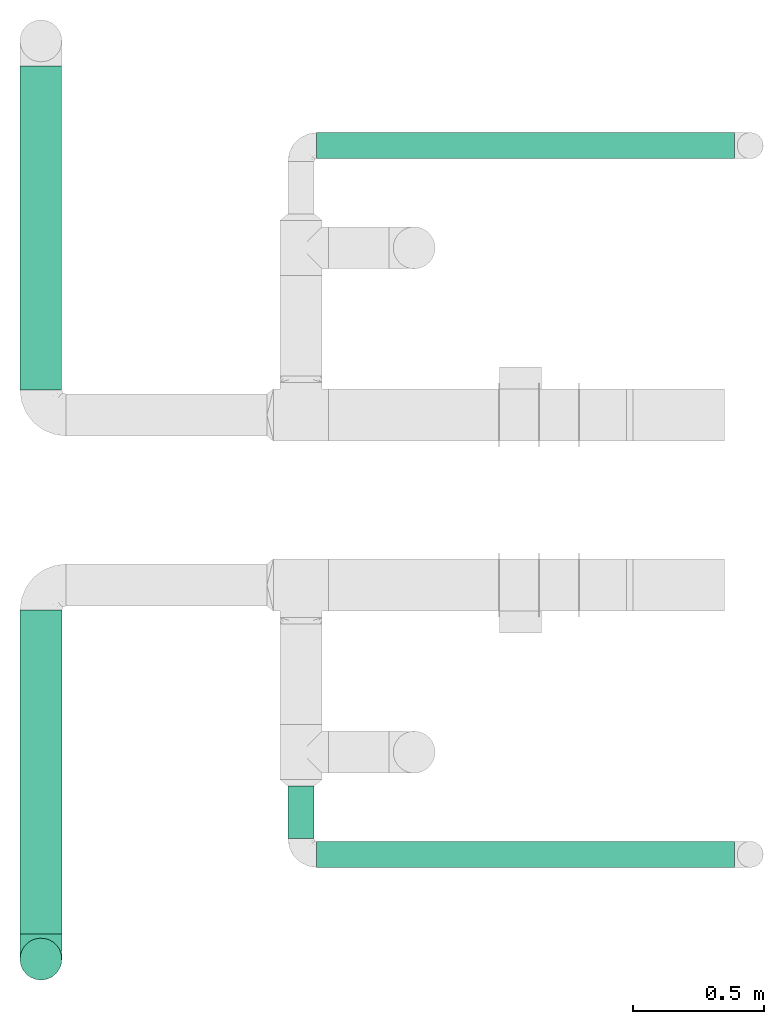
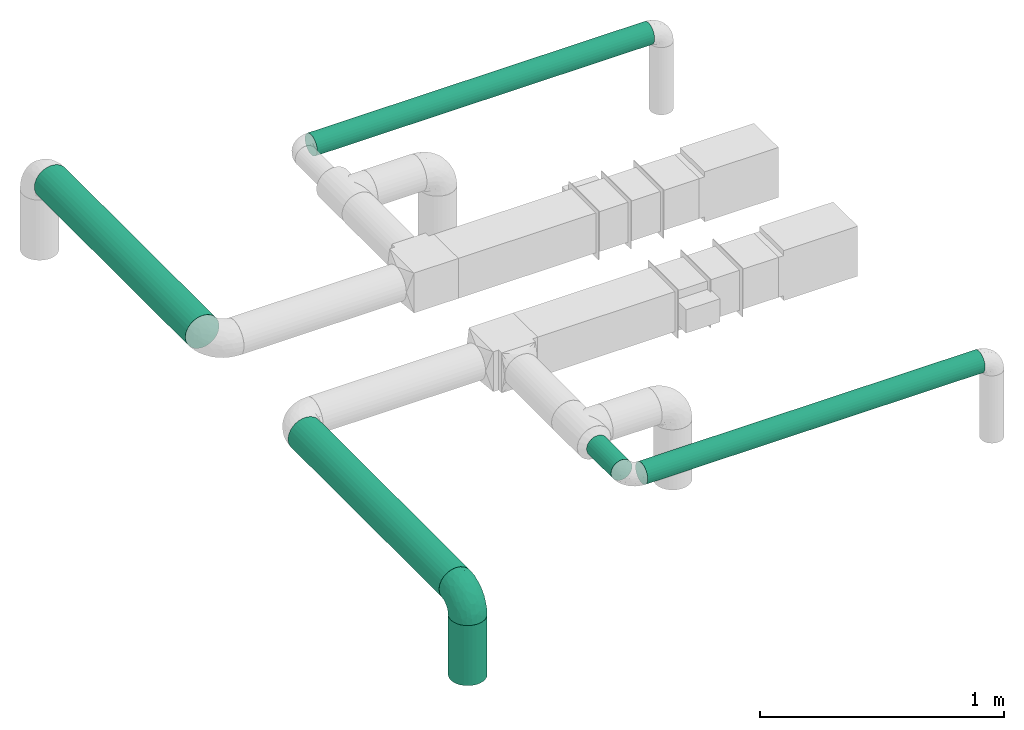
# One storey, part 1 of 12: 6 flow segments, 1 flow fitting.
"""IFC2X3 building model written with IfcOpenShell, lengths in millimetres."""

from ifc_helpers import new_model, entity, si_unit, converted_unit, derived_unit, direction, frame, frame_2d, origin, origin_2d_with_axis, place, context, subcontext, project, spatial, circle, extrude, faceted_brep, source, transform, mapped, type_object, type_shapes, element, save


model = new_model("IFC2X3")

# Units and contexts
model_context = context("Model", 3, precision=0.01, world=origin(), true_north=direction((6.12303176911189e-17, 1.0)))
body_context = subcontext(model_context, "Body", "Model", "MODEL_VIEW")
ifc_project = project(units=[si_unit("LENGTHUNIT", "METRE", prefix="MILLI"), si_unit("AREAUNIT", "SQUARE_METRE"), si_unit("VOLUMEUNIT", "CUBIC_METRE"), converted_unit("PLANEANGLEUNIT", "DEGREE", entity("IfcRatioMeasure", 0.0174532925199433), si_unit("PLANEANGLEUNIT", "RADIAN"), dimensions=[0, 0, 0, 0, 0, 0, 0]), si_unit("MASSUNIT", "GRAM", prefix="KILO"), derived_unit("MASSDENSITYUNIT", [(si_unit("MASSUNIT", "GRAM", prefix="KILO"), 1), (si_unit("LENGTHUNIT", "METRE"), -3)]), si_unit("TIMEUNIT", "SECOND"), si_unit("FREQUENCYUNIT", "HERTZ"), si_unit("THERMODYNAMICTEMPERATUREUNIT", "DEGREE_CELSIUS"), derived_unit("THERMALTRANSMITTANCEUNIT", [(si_unit("MASSUNIT", "GRAM", prefix="KILO"), 1), (si_unit("THERMODYNAMICTEMPERATUREUNIT", "KELVIN"), -1), (si_unit("TIMEUNIT", "SECOND"), -3)]), derived_unit("VOLUMETRICFLOWRATEUNIT", [(si_unit("LENGTHUNIT", "METRE"), 3), (si_unit("TIMEUNIT", "SECOND"), -1)]), si_unit("ELECTRICCURRENTUNIT", "AMPERE"), si_unit("ELECTRICVOLTAGEUNIT", "VOLT"), si_unit("POWERUNIT", "WATT"), si_unit("FORCEUNIT", "NEWTON", prefix="KILO"), si_unit("ILLUMINANCEUNIT", "LUX"), si_unit("LUMINOUSFLUXUNIT", "LUMEN"), si_unit("LUMINOUSINTENSITYUNIT", "CANDELA"), derived_unit("USERDEFINED", [(si_unit("MASSUNIT", "GRAM", prefix="KILO"), -1), (si_unit("LENGTHUNIT", "METRE"), -2), (si_unit("TIMEUNIT", "SECOND"), 3), (si_unit("LUMINOUSFLUXUNIT", "LUMEN"), 1)]), derived_unit("LINEARVELOCITYUNIT", [(si_unit("LENGTHUNIT", "METRE"), 1), (si_unit("TIMEUNIT", "SECOND"), -1)]), si_unit("PRESSUREUNIT", "PASCAL"), derived_unit("USERDEFINED", [(si_unit("LENGTHUNIT", "METRE"), -2), (si_unit("MASSUNIT", "GRAM", prefix="KILO"), 1), (si_unit("TIMEUNIT", "SECOND"), -2)])], contexts=[model_context])

# Site, building, storey
site_placement = place(None, origin())
site = spatial("IfcSite", under=ifc_project, at=site_placement, CompositionType="ELEMENT")
building_placement = place(site_placement, origin())
building = spatial("IfcBuilding", under=site, at=building_placement, CompositionType="ELEMENT")
storey_placement = place(building_placement, frame((0.0, 0.0, 8000.0)))
storey = spatial("IfcBuildingStorey", under=building, at=storey_placement, Name="02 Level", CompositionType="ELEMENT", Elevation=8000.0)

# Flow segments
duct_segment_type = type_object("IfcDuctSegmentType", Name="Round Duct:Air", PredefinedType="NOTDEFINED")
flow_segment_1_placement = place(storey_placement, frame((23245.9900708518, -70237.5308847274, 2948.40472776403)))
element("IfcFlowSegment", 1, at=flow_segment_1_placement, inside=storey, type_object=duct_segment_type, Name="Round Duct:Air", ObjectType="Round Duct:Air", context=body_context, shape_type="SweptSolid", body=[
    extrude(circle(Radius=50.0, at=origin_2d_with_axis()), frame((0.0, 51.5952722359132, 51.5952722359154), z_axis=(1.0, 0.0, 0.0), x_axis=(0.0, -1.0, 0.0)), (0.0, 0.0, 1.0), 1597.50000000001),
])
flow_segment_2_placement = place(storey_placement, frame((22110.1537099681, -70490.2395851399, 2918.40472776409)))
element("IfcFlowSegment", 2, at=flow_segment_2_placement, inside=storey, type_object=duct_segment_type, Name="Round Duct:Air", ObjectType="Round Duct:Air", context=body_context, shape_type="SweptSolid", body=[
    extrude(circle(Radius=80.0, at=origin_2d_with_axis()), frame((81.595272235915, 0.0, 81.595272235915), z_axis=(0.0, 1.0, 0.0), x_axis=(1.0, 0.0, 0.0)), (0.0, 0.0, 1.0), 1238.20435582267),
])
flow_segment_3_placement = place(storey_placement, frame((22110.1537099681, -70667.8348573758, 2603.07847999999)))
element("IfcFlowSegment", 3, at=flow_segment_3_placement, inside=storey, type_object=duct_segment_type, Name="Round Duct:Air", ObjectType="Round Duct:Air", context=body_context, shape_type="SweptSolid", body=[
    extrude(circle(Radius=79.9999999999999, at=origin_2d_with_axis()), frame((81.595272235915, 81.595272235915, 0.0), z_axis=(0.0, 0.0, 1.0), x_axis=(-1.0, 0.0, 0.0)), (0.0, 0.0, 1.0), 300.921520000008),
])
flow_segment_4_placement = place(storey_placement, frame((23134.3947986159, -70125.9356124915, 2948.40472776403)))
element("IfcFlowSegment", 4, at=flow_segment_4_placement, inside=storey, type_object=duct_segment_type, Name="Round Duct:Air", ObjectType="Round Duct:Air", context=body_context, shape_type="SweptSolid", body=[
    extrude(circle(Radius=50.0, at=origin_2d_with_axis()), frame((51.5952722359175, 0.0, 51.5952722359154), z_axis=(0.0, 1.0, 0.0), x_axis=(1.0, 0.0, 0.0)), (0.0, 0.0, 1.0), 200.701380999497),
])
flow_segment_5_placement = place(storey_placement, frame((23245.9900708518, -67528.1388300243, 2948.40472776403)))
element("IfcFlowSegment", 5, at=flow_segment_5_placement, inside=storey, type_object=duct_segment_type, Name="Round Duct:Air", ObjectType="Round Duct:Air", context=body_context, shape_type="SweptSolid", body=[
    extrude(circle(Radius=50.0, at=origin_2d_with_axis()), frame((0.0, 51.5952722359305, 51.5952722359154), z_axis=(1.0, 0.0, 0.0), x_axis=(0.0, -1.0, 0.0)), (0.0, 0.0, 1.0), 1597.50000000001),
])
flow_segment_6_placement = place(storey_placement, frame((22110.1537099681, -68410.4439409626, 2918.40472776409)))
element("IfcFlowSegment", 6, at=flow_segment_6_placement, inside=storey, type_object=duct_segment_type, Name="Round Duct:Air", ObjectType="Round Duct:Air", context=body_context, shape_type="SweptSolid", body=[
    extrude(circle(Radius=80.0, at=frame_2d((-4.33146851719357e-12, 0.0), x_axis=(1.0, 0.0))), frame((81.5952722359194, 0.0, 81.595272235915), z_axis=(0.0, 1.0, 0.0), x_axis=(-1.0, 0.0, 0.0)), (0.0, 0.0, 1.0), 1238.20435582267),
])

# Flow fitting
duct_fitting_type = type_object("IfcDuctFittingType", Name="Air_Elbow short_Circ", PredefinedType="NOTDEFINED")
shared_shape = source(origin(), body_context, "Body", "Brep", [
    faceted_brep([(-96.0, 40.0, -69.2820323027551), (-96.0, 20.7055236082018, -77.2740661031254), (-96.0, 0.0, -80.0), (-96.0, -20.7055236082015, -77.2740661031255), (-96.0, -40.0, -69.2820323027552), (-96.0, -56.5685424949237, -56.5685424949239), (-96.0, -69.282032302755, -40.0), (-96.0, -77.2740661031254, -20.7055236082019), (-96.0, -80.0, 0.0), (-96.0, -77.2740661031256, 20.7055236082014), (-96.0, -69.2820323027553, 40.0), (-96.0, -56.568542494924, 56.5685424949236), (-96.0, -40.0, 69.2820323027549), (-96.0, -20.705523608202, 77.2740661031254), (-96.0, 0.0, 80.0), (-96.0, 20.7055236082013, 77.2740661031256), (-96.0, 30.3527618041005, 73.2780492029404), (-96.0, 40.0, 69.2820323027553), (-96.0, 56.5685424949235, 56.5685424949241), (-96.0, 69.2820323027549, 40.0), (-96.0, 77.2740661031253, 20.7055236082021), (-96.0, 80.0, 0.0), (-96.0, 77.2740661031255, -20.7055236082016), (-96.0, 69.2820323027551, -40.0), (-96.0, 56.5685424949239, -56.5685424949238), (0.0, 96.0, -80.0), (-20.7055236082008, 96.0, -77.2740661031254), (-30.3527618041, 96.0, -73.2780492029402), (-40.0, 96.0, -69.2820323027551), (-56.5685424949229, 96.0, -56.5685424949238), (-69.2820323027542, 96.0, -40.0), (-77.2740661031245, 96.0, -20.7055236082016), (-80.0, 96.0, 0.0), (-77.2740661031244, 96.0, 20.7055236082021), (-69.2820323027539, 96.0, 40.0), (-56.5685424949226, 96.0, 56.5685424949241), (-40.0, 96.0, 69.2820323027553), (-20.7055236082004, 96.0, 77.2740661031256), (0.0, 96.0, 80.0), (20.7055236082029, 96.0, 77.2740661031254), (40.0, 96.0, 69.2820323027549), (56.5685424949249, 96.0, 56.5685424949236), (69.2820323027562, 96.0, 40.0), (77.2740661031265, 96.0, 20.7055236082014), (80.0, 96.0, 0.0), (77.2740661031264, 96.0, -20.7055236082019), (69.2820323027559, 96.0, -40.0), (56.5685424949246, 96.0, -56.5685424949239), (40.0, 96.0, -69.2820323027552), (20.7055236082025, 96.0, -77.2740661031255), (-69.6571465232348, 6.28172173912476, 79.9611058756859), (-55.1380888291464, -64.4450584799279, 39.5029426177976), (-78.4902527850466, -65.2482264041437, 44.9229732355936), (-66.7862289407348, -74.1387210661139, 22.9795507758541), (-79.9123689128389, 22.4151301859584, 77.2816866630488), (-75.1250134759213, 46.3506195730757, 68.0011973810265), (-46.2820694578435, -43.7397705581167, 60.5188244193914), (-62.9760666105318, -34.5362195419601, 70.0448030595901), (-67.1316735243184, -51.7530432423058, 58.5204707533666), (-50.4478480619551, -74.0029454268759, 0.0), (-76.2276812833835, -77.3969248578635, 0.0), (-27.189372084162, 68.980536479128, 76.8941402015288), (-6.30632028234235, 70.6421404093778, 79.9513108199466), (-47.7584488981354, -13.6212410427434, 76.3881123659885), (-29.8609237116382, -28.9682345099716, 65.8760199345924), (57.6005967886466, 33.4719572927763, 39.0176496769077), (51.7530435574228, 67.1316742002235, 58.5204705859065), (43.7397637815864, 46.2820598522933, 60.518827155348), (-74.2591571701267, -14.3645886695287, 78.2829835259588), (28.4507934888335, -28.4507934888321, 0.0), (23.3846344985257, -27.9066135199674, 24.7887114209846), (7.8513563843086, -42.4938374080907, 21.3232874317503), (-84.190871651952, 70.905997349447, 41.7100461919055), (24.7272484782103, -2.06889411058577, 53.4325037134459), (-0.0180155578363953, -25.9284255475521, 53.836744023285), (10.21505333872, -32.0754161621096, 38.020212353501), (-64.5619855594544, 27.52018553659, 77.2892967298799), (-41.7574890626937, 15.123136403511, 79.988056483004), (-24.5336756868846, -60.9669573051438, 23.5003835585885), (-29.2239240309769, -65.2117082464685, 0.0), (-8.0, -56.420471066061, 0.0), (-16.4008295437786, 51.3122057461681, 79.8609584412684), (-83.0529092063249, 83.0529092103045, 19.0855009657076), (-84.6862915010143, 84.6862915010152, 0.0), (-82.4185651555764, 62.2587017800419, 53.3339952483838), (-46.3022193149449, 75.902750025661, 67.8445262622594), (-9.5260688639158, -47.7232209131232, 35.4187162694583), (74.1387213421635, 66.7862279048973, 22.9795492840646), (14.3645870599314, 74.259154996167, 78.2829837700474), (34.536215572589, 62.976064096567, 70.0448048426748), (65.2482273833467, 78.4902510979302, 44.9229715327465), (-12.3935655196116, 25.4017250572252, 78.8652642576962), (-25.6317751341749, 1.2640655514879, 76.9124052095498), (69.8186739706361, 42.5625104806759, 16.7980672722629), (64.4450597015273, 55.1380839274934, 39.5029384026545), (60.9669574479924, 24.5336725945725, 23.5003789659965), (77.3969247188647, 76.2276802275763, 0.0), (74.002945426877, 50.4478480619565, 0.0), (-66.5995156060253, 66.5995146556305, 58.6370817132137), (-52.4774893100348, 53.0631556360015, 72.0041598972686), (-76.4857465466113, 78.9385356944492, 38.5867538667356), (-62.2587016209511, 82.4185645906685, 53.3339956492136), (28.9682276847195, 29.8609133580269, 65.8760207540895), (13.6212369177471, 47.7584433090926, 76.3881128402526), (-6.49930484510329, -53.7890406240985, 15.4645725223014), (-33.731289034344, 40.0214486160993, 79.0537019298314), (46.1336936566893, 26.2441492635858, 50.151541479116), (42.4356322774479, -10.225396744416, 0.0), (56.4204710660622, 8.0, 0.0), (50.0005984633279, 1.26038287501495, 17.5763945268078), (-45.4536887619888, -68.8356359385787, 23.6914879663761), (-33.3493864711472, -57.4572215948989, 39.1720709545353), (35.9683398342664, -11.0724559744972, 30.5391080332169), (-26.2441652621668, -46.1336984778153, 50.1515448602929), (36.6749123583047, -17.5982116941791, 14.5644188861001), (65.2117082464696, 29.2239240309784, 0.0), (49.5968730216335, 12.1440064858134, 34.8325942562253), (-47.1533280807863, 29.0746114834461, 78.9127210009486), (-0.981722938535007, 51.3162880079176, 79.4920802366619), (12.4951682569875, 20.0804783439543, 71.2292489374933), (-1.95170750213435, 1.95169859379814, 70.9272590604952), (13.0725391330592, 1.13338064801589, 63.5790506070627), (-1.93327092594732, -13.4823821925323, 63.7412032706882), (-18.9298205951927, -13.0048872663631, 70.6672094580024), (10.2253967444173, -42.4356322774466, 0.0), (-68.9805369123341, 27.1893702897943, -76.8941406355589), (-22.4151342180024, 79.9123577737124, -77.2816862456941), (-27.5201921618733, 64.5619784506715, -77.2892959136582), (-46.3506180288022, 75.1250185023919, -68.0011970559212), (-74.2591561090454, -14.364589592643, -78.2829832920378), (-42.5625109127564, -69.8186736490614, -16.7980693145318), (-66.78622820047, -74.1387209331735, -22.9795507950237), (-70.6421421271429, 6.30631801763141, -79.9513108797024), (-25.401718902627, 12.3935649209934, -78.8652635038296), (-15.1231475192353, 41.7574898106582, -79.9880566497423), (-1.2640784754681, 25.6317655571971, -76.9124065444174), (-78.9385361639639, 76.4857467527193, -38.5867530236755), (-66.5995166501766, 66.5995137008527, -58.6370816545605), (-82.4185656924104, 62.258701559575, -53.3339952529289), (60.9669567069012, 24.5336743104721, -23.5003834743896), (53.7890400497189, 6.49930371043273, -15.4645720709197), (-55.1380878256228, -64.4450583029017, -39.5029424837467), (-24.5336751436549, -60.9669572920351, -23.5003828649414), (-29.8609212227281, -28.9682353164184, -65.8760186412515), (-26.2441631797834, -46.1336980827234, -50.1515441608816), (-46.2820677406335, -43.7397707662098, -60.5188237522514), (74.1387206827049, 66.7862275406284, -22.9795512458422), (-40.0214489824224, 33.7312845774564, -79.0537024061946), (-78.4902524468744, -65.2482264004152, -44.9229731872606), (-75.902751427461, 46.3022186029078, -67.8445263463497), (-70.9059970555813, 84.1908706304995, -41.7100473389448), (-67.1316724627346, -51.7530434014037, -58.5204704180807), (-62.9760652707231, -34.536220162299, -70.044802546446), (-33.4719630839568, -57.6005950429912, -39.0176564793206), (-51.3122062597491, 16.4008248291117, -79.8609586691244), (-6.28171714934502, 69.65712797409, -79.9611061760713), (51.7530427306645, 67.1316703492073, -58.5204706539109), (-83.0529092397056, 83.0529091932979, -19.0855009185769), (68.8356349913375, 45.45368838847, -23.6914905340598), (-62.258701383479, 82.4185638376438, -53.3339962098694), (34.53621889603, 62.9760621802168, -70.0448028055675), (-1.26038544288408, -50.0005998980998, -17.5763953891677), (13.6212385978137, 47.75844096294, -76.3881120677864), (14.3645887716112, 74.2591526334116, -78.2829833202131), (65.2482261461557, 78.4902526871683, -44.9229735979605), (2.068884460932, -24.7272580800759, -53.4325021883878), (25.9284207554091, 0.0180077987247146, -53.8367428868672), (32.0754071702863, -10.2150656939878, -38.0202105656364), (47.723215348146, 9.52606271707191, -35.4187195087105), (27.9066094773716, -23.3846413342612, -24.7887058003424), (42.4938359077841, -7.8513587520169, -21.3232866357369), (28.9682309044935, 29.8609168472814, -65.8760199178674), (64.4450577206072, 55.1380878066959, -39.5029434692504), (-53.063150048133, 52.4774843719861, -72.0041634993662), (43.7397687897612, 46.2820667462245, -60.5188250739327), (-47.7584463040963, -13.6212426330217, -76.3881115880261), (57.4572201066452, 33.3493827160302, -39.1720708806551), (11.0724494499294, -35.9683446288498, -30.5391089716619), (46.1336964749623, 26.2441642243134, -50.1515465265606), (17.5982028158329, -36.6749194460897, -14.5644209948051), (-12.1440097531109, -49.5968729214507, -34.8325978072281), (-29.0746218055845, 47.1533256390974, -78.912719851915), (-51.3162911259858, 0.981717610547608, -79.4920798409907), (-20.0804667507281, -12.4951842966219, -71.2292388196267), (-1.95170139871169, 1.95169735730944, -70.9272563527003), (-1.13337124471279, -13.072540998247, -63.5790448193562), (13.4823844636247, 1.93327501577089, -63.7412039856557), (13.0048800657406, 18.9298191902065, -70.6672121474654)], [[[0, 1, 2, 3, 4, 5, 6, 7, 8, 9, 10, 11, 12, 13, 14, 15, 16, 17, 18, 19, 20, 21, 22, 23, 24]], [[25, 26, 27, 28, 29, 30, 31, 32, 33, 34, 35, 36, 37, 38, 39, 40, 41, 42, 43, 44, 45, 46, 47, 48, 49]], [[15, 14, 50]], [[51, 52, 53]], [[54, 55, 17]], [[56, 57, 58]], [[59, 53, 60]], [[37, 61, 62]], [[63, 57, 64]], [[65, 66, 67]], [[52, 11, 10]], [[58, 57, 12]], [[68, 14, 13]], [[69, 70, 71]], [[72, 20, 19]], [[57, 63, 68]], [[73, 74, 75]], [[76, 50, 77]], [[13, 12, 57]], [[17, 55, 18]], [[17, 16, 15, 54]], [[78, 79, 80]], [[81, 62, 61]], [[21, 82, 83]], [[57, 56, 64]], [[21, 20, 82]], [[84, 72, 19]], [[12, 11, 58]], [[19, 18, 84]], [[36, 85, 61]], [[75, 74, 86]], [[53, 9, 60]], [[53, 10, 9]], [[42, 87, 43]], [[66, 41, 40]], [[88, 89, 39]], [[42, 41, 90]], [[40, 39, 89]], [[91, 77, 92]], [[87, 42, 90]], [[93, 94, 95]], [[89, 66, 40]], [[87, 96, 43]], [[36, 35, 85]], [[93, 97, 87]], [[85, 98, 99]], [[33, 100, 34]], [[82, 100, 33]], [[100, 98, 101]], [[102, 89, 103]], [[83, 82, 32]], [[78, 80, 104]], [[36, 61, 37]], [[61, 85, 99]], [[105, 77, 91]], [[102, 106, 67]], [[35, 34, 101]], [[37, 62, 38]], [[107, 108, 109]], [[110, 51, 53]], [[88, 39, 38]], [[78, 110, 79]], [[59, 79, 110]], [[51, 110, 111]], [[75, 70, 112]], [[111, 86, 113]], [[107, 114, 69]], [[106, 102, 73]], [[115, 93, 95]], [[62, 88, 38]], [[115, 95, 108]], [[116, 95, 65]], [[95, 116, 109]], [[68, 50, 14]], [[76, 77, 117]], [[76, 117, 99]], [[84, 55, 98]], [[101, 85, 35]], [[98, 55, 99]], [[81, 61, 105]], [[62, 118, 88]], [[67, 66, 89]], [[90, 66, 94]], [[52, 58, 11]], [[58, 51, 111]], [[50, 63, 77]], [[92, 77, 63]], [[119, 91, 120]], [[81, 118, 62]], [[120, 121, 119]], [[73, 112, 116]], [[120, 122, 121]], [[123, 122, 120]], [[74, 64, 113]], [[92, 123, 120]], [[74, 113, 86]], [[73, 121, 122]], [[76, 99, 55]], [[61, 99, 105]], [[9, 8, 60]], [[96, 87, 97]], [[96, 44, 43]], [[89, 88, 103]], [[57, 68, 13]], [[50, 68, 63]], [[100, 101, 34]], [[85, 101, 98]], [[55, 84, 18]], [[72, 98, 100]], [[105, 91, 81]], [[118, 91, 103]], [[91, 118, 81]], [[88, 118, 103]], [[98, 72, 84]], [[72, 100, 82]], [[82, 20, 72]], [[32, 82, 33]], [[53, 52, 10]], [[58, 52, 51]], [[66, 90, 41]], [[87, 90, 94]], [[76, 55, 54]], [[15, 50, 54]], [[50, 76, 54]], [[110, 53, 59]], [[111, 110, 78]], [[78, 104, 86]], [[111, 113, 56]], [[78, 86, 111]], [[86, 71, 75]], [[70, 75, 71]], [[73, 75, 112]], [[104, 124, 71]], [[95, 109, 108]], [[70, 114, 112]], [[94, 65, 95]], [[114, 109, 112]], [[69, 114, 70]], [[109, 114, 107]], [[73, 116, 106]], [[112, 109, 116]], [[66, 65, 94]], [[106, 116, 65]], [[97, 93, 115]], [[86, 104, 71]], [[124, 104, 80]], [[124, 69, 71]], [[94, 93, 87]], [[102, 67, 89]], [[65, 67, 106]], [[111, 56, 58]], [[64, 56, 113]], [[77, 105, 117]], [[99, 117, 105]], [[123, 63, 64]], [[91, 92, 120]], [[63, 123, 92]], [[122, 64, 74]], [[64, 122, 123]], [[73, 122, 74]], [[73, 102, 121]], [[119, 121, 102]], [[102, 103, 119]], [[91, 119, 103]], [[0, 125, 1]], [[126, 127, 128]], [[3, 2, 129]], [[130, 59, 131]], [[1, 132, 2]], [[133, 134, 135]], [[136, 137, 138]], [[139, 108, 140]], [[23, 138, 24]], [[130, 141, 142]], [[23, 22, 136]], [[143, 144, 145]], [[146, 46, 45]], [[147, 134, 133]], [[131, 6, 148]], [[0, 24, 149]], [[131, 60, 7]], [[150, 31, 30]], [[151, 4, 152]], [[153, 151, 145]], [[5, 4, 151]], [[4, 3, 152]], [[154, 132, 125]], [[5, 148, 6]], [[26, 25, 155]], [[3, 129, 152]], [[6, 131, 7]], [[48, 47, 156]], [[21, 83, 157]], [[139, 158, 115]], [[32, 31, 157]], [[157, 136, 22]], [[30, 159, 150]], [[49, 48, 160]], [[124, 80, 161]], [[29, 159, 30]], [[28, 27, 26, 126]], [[149, 125, 0]], [[127, 155, 134]], [[160, 162, 163]], [[164, 47, 46]], [[29, 28, 128]], [[165, 166, 167]], [[49, 163, 25]], [[168, 167, 166]], [[1, 125, 132]], [[139, 115, 108]], [[69, 169, 170]], [[162, 160, 171]], [[156, 160, 48]], [[172, 164, 146]], [[149, 137, 173]], [[146, 96, 97]], [[160, 174, 171]], [[143, 152, 175]], [[156, 174, 160]], [[125, 149, 173]], [[126, 128, 28]], [[97, 115, 158]], [[157, 22, 21]], [[158, 172, 146]], [[146, 45, 96]], [[172, 158, 176]], [[167, 169, 177]], [[176, 168, 178]], [[124, 179, 69]], [[144, 143, 165]], [[79, 130, 142]], [[45, 44, 96]], [[79, 142, 80]], [[180, 142, 153]], [[142, 180, 161]], [[163, 155, 25]], [[181, 134, 147]], [[127, 181, 173]], [[159, 128, 137]], [[138, 149, 24]], [[137, 128, 173]], [[154, 125, 147]], [[132, 182, 129]], [[145, 151, 152]], [[148, 151, 141]], [[164, 156, 47]], [[156, 172, 176]], [[155, 162, 134]], [[135, 134, 162]], [[183, 133, 184]], [[154, 182, 132]], [[184, 185, 183]], [[165, 177, 180]], [[184, 186, 185]], [[187, 186, 184]], [[166, 171, 178]], [[135, 187, 184]], [[166, 178, 168]], [[165, 185, 186]], [[127, 173, 128]], [[125, 173, 147]], [[60, 131, 59]], [[60, 8, 7]], [[132, 129, 2]], [[152, 129, 175]], [[160, 163, 49]], [[155, 163, 162]], [[136, 138, 23]], [[149, 138, 137]], [[128, 159, 29]], [[150, 137, 136]], [[147, 133, 154]], [[182, 133, 175]], [[133, 182, 154]], [[129, 182, 175]], [[137, 150, 159]], [[150, 136, 157]], [[32, 157, 83]], [[157, 31, 150]], [[146, 164, 46]], [[156, 164, 172]], [[151, 148, 5]], [[131, 148, 141]], [[127, 126, 155]], [[26, 155, 126]], [[158, 146, 97]], [[176, 158, 139]], [[139, 140, 168]], [[176, 178, 174]], [[139, 168, 176]], [[168, 170, 167]], [[169, 167, 170]], [[165, 167, 177]], [[140, 107, 170]], [[142, 161, 80]], [[169, 179, 177]], [[141, 153, 142]], [[179, 161, 177]], [[69, 179, 169]], [[161, 179, 124]], [[165, 180, 144]], [[177, 161, 180]], [[151, 153, 141]], [[144, 180, 153]], [[59, 130, 79]], [[168, 140, 170]], [[107, 140, 108]], [[107, 69, 170]], [[141, 130, 131]], [[143, 145, 152]], [[153, 145, 144]], [[176, 174, 156]], [[171, 174, 178]], [[173, 181, 147]], [[127, 134, 181]], [[187, 162, 171]], [[133, 135, 184]], [[162, 187, 135]], [[186, 171, 166]], [[171, 186, 187]], [[165, 186, 166]], [[165, 143, 185]], [[183, 185, 143]], [[143, 175, 183]], [[133, 183, 175]]]),
])
type_shapes(duct_fitting_type, [shared_shape])
flow_fitting_placement = place(storey_placement, frame((22191.748982204, -70586.2395851399, 3000.0), z_axis=(-1.0, 0.0, 0.0), x_axis=(0.0, 0.0, 1.0)))
element("IfcFlowFitting", 7, at=flow_fitting_placement, inside=storey, type_object=duct_fitting_type, Name="elbow_short_001:Air_Elbow short_Circ", ObjectType="elbow_short_001:Air_Elbow short_Circ", context=body_context, shape_type="MappedRepresentation", body=[
    mapped(shared_shape, transform((0.0, 0.0, 0.0), scale=1.0)),
])

save(model, "model.ifc")
